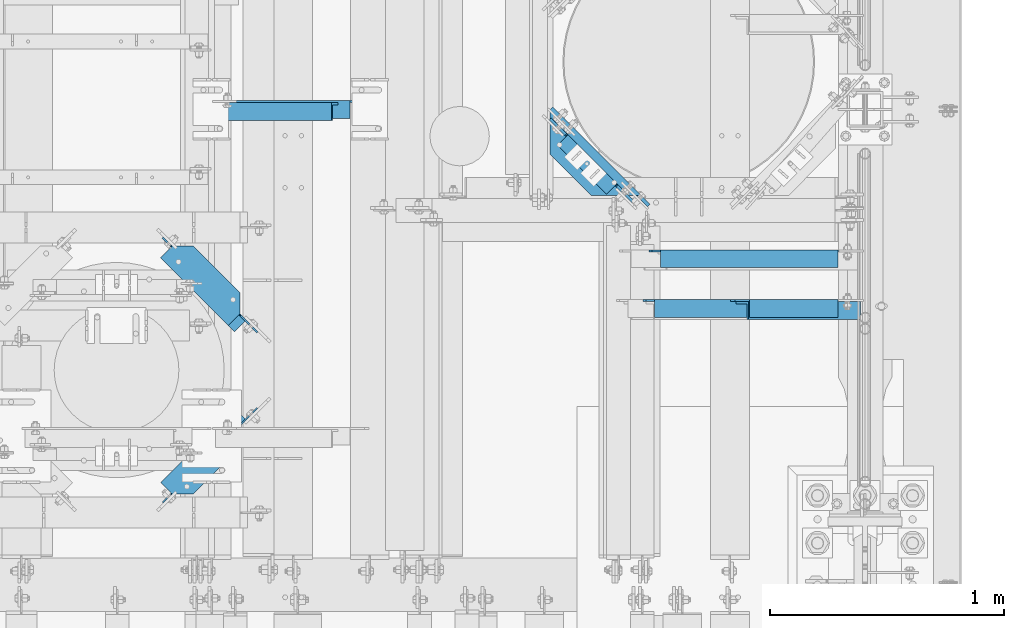
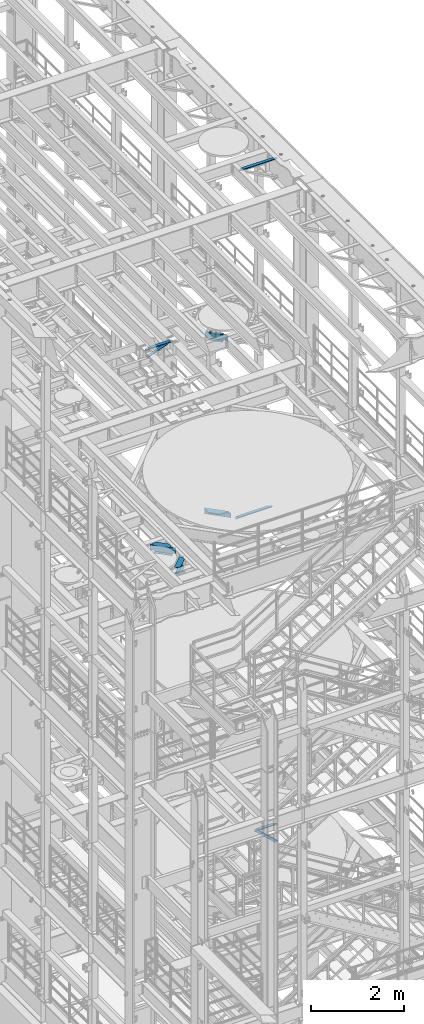
# One storey, part 1260 of 1876: 8 beams, 2 members, 10 elements without a shape of their own.
"""IFC2X3 building model written with IfcOpenShell, lengths in millimetres."""

from ifc_helpers import new_model, si_unit, frame, origin_with_axes, place, context, subcontext, project, spatial, faceted_brep, material, type_object, element, aggregate, save


model = new_model("IFC2X3")

# Units and contexts
model_context = context("Model", 3, precision=1e-05, world=origin_with_axes())
body_context = subcontext(model_context, "Body", "Model", "MODEL_VIEW")
ifc_project = project(units=[si_unit("LENGTHUNIT", "METRE", prefix="MILLI"), si_unit("AREAUNIT", "SQUARE_METRE"), si_unit("VOLUMEUNIT", "CUBIC_METRE"), si_unit("MASSUNIT", "GRAM", prefix="KILO"), si_unit("TIMEUNIT", "SECOND"), si_unit("PLANEANGLEUNIT", "RADIAN"), si_unit("SOLIDANGLEUNIT", "STERADIAN"), si_unit("THERMODYNAMICTEMPERATUREUNIT", "DEGREE_CELSIUS"), si_unit("LUMINOUSINTENSITYUNIT", "LUMEN")], contexts=[model_context])

# Site, building, storey
site_placement = place(None, origin_with_axes())
site = spatial("IfcSite", under=ifc_project, at=site_placement, CompositionType="ELEMENT")
building_placement = place(site_placement, origin_with_axes())
building = spatial("IfcBuilding", under=site, at=building_placement, Name="Undefined", CompositionType="ELEMENT")
storey_placement = place(building_placement, origin_with_axes())
storey = spatial("IfcBuildingStorey", under=building, at=storey_placement, Name="Undefined", CompositionType="ELEMENT", Elevation=0.0)

# Assembly, member
assembly_1_placement = place(storey_placement, origin_with_axes())
assembly_1 = element("IfcElementAssembly", 1, at=assembly_1_placement, inside=storey, AssemblyPlace="NOTDEFINED", PredefinedType="RIGID_FRAME")
ifc_material_1 = material(Name="STEEL/A36")
member_type = type_object("IfcMemberType", Name="L3X3X3/8", PredefinedType="NOTDEFINED")
member_1_placement = place(assembly_1_placement, frame((4825.99943782548, 3546.47297112884, 17722.85), z_axis=(0.0, -1.0, 0.0), x_axis=(0.933232749162593, -9.69999853849769e-08, 0.35927237006263)))
member_1 = element("IfcMember", 2, at=member_1_placement, type_object=member_type, material=ifc_material_1, ObjectType="L3X3X3/8", context=body_context, shape_type="Brep", body=[
    faceted_brep([(31.6783539145181, 38.0999999999167, -38.1000000000035), (31.6783539102435, 38.1000000000477, 38.0999999999967), (563.830812318436, 38.100000000677, 38.0999999999349), (563.830812322711, 38.1000000005497, -38.1000000000654), (31.6783539102325, 28.5750000000644, 38.0999999999967), (563.830812318425, 28.5750000006938, 38.0999999999349), (31.6783539139742, 28.5749999999498, -28.5750000000039), (563.830812322169, 28.575000000581, -28.5750000000658), (31.6783539139069, -38.0999999999422, -28.5750000000044), (563.830812322098, -38.0999999993164, -28.5750000000662), (31.6783539144417, -38.099999999964, -38.1000000000045), (563.830812322634, -38.0999999993292, -38.1000000000663)], [[[0, 1, 2, 3]], [[1, 4, 5, 2]], [[4, 6, 7, 5]], [[6, 8, 9, 7]], [[8, 10, 11, 9]], [[10, 0, 3, 11]], [[5, 7, 9, 11, 3, 2]], [[10, 8, 6, 4, 1, 0]]]),
])
aggregate(assembly_1, [member_1])

assembly_2_placement = place(storey_placement, origin_with_axes())
assembly_2 = element("IfcElementAssembly", 3, at=assembly_2_placement, inside=storey, AssemblyPlace="NOTDEFINED", PredefinedType="RIGID_FRAME")
member_2_placement = place(assembly_2_placement, frame((7042.14884555327, 2695.575, 5130.79999999686), z_axis=(0.0, -1.0, 0.0), x_axis=(0.726792308030797, 0.0, -0.686857293029104)))
member_2 = element("IfcMember", 4, at=member_2_placement, type_object=member_type, material=ifc_material_1, ObjectType="L3X3X3/8", context=body_context, shape_type="Brep", body=[
    faceted_brep([(72.6727188348357, 38.100000000004, -38.0999999999999), (72.6727188348357, 38.100000000004, 38.0999999999999), (731.760828651386, 38.1000000001059, 38.0999999999999), (731.760828651386, 38.1000000001059, -38.0999999999999), (72.6727188348361, 28.5750000000062, 38.0999999999999), (731.760828651386, 28.5750000001062, 38.0999999999999), (72.6727188348361, 28.5750000000062, -28.5749999999998), (731.760828651386, 28.5750000001062, -28.5749999999998), (72.6727188348361, -38.0999999999822, -28.5749999999998), (731.760828651387, -38.0999999998821, -28.5749999999998), (72.6727188348361, -38.0999999999822, -38.0999999999999), (731.760828651387, -38.0999999998821, -38.0999999999999)], [[[0, 1, 2, 3]], [[1, 4, 5, 2]], [[4, 6, 7, 5]], [[6, 8, 9, 7]], [[8, 10, 11, 9]], [[10, 0, 3, 11]], [[5, 7, 9, 11, 3, 2]], [[10, 8, 6, 4, 1, 0]]]),
])
aggregate(assembly_2, [member_2])

# Assembly, beam
assembly_3_placement = place(storey_placement, origin_with_axes())
assembly_3 = element("IfcElementAssembly", 5, at=assembly_3_placement, inside=storey, Name="ANGLE", AssemblyPlace="NOTDEFINED", PredefinedType="RIGID_FRAME")
beam_type_1 = type_object("IfcBeamType", Name="L3X3X3/8", PredefinedType="NOTDEFINED")
beam_1_placement = place(assembly_3_placement, frame((4826.00006225236, 3555.99797112877, 17945.1), z_axis=(0.0, -1.0, 0.0), x_axis=(1.0, 0.0, 0.0)))
beam_1 = element("IfcBeam", 6, at=beam_1_placement, type_object=beam_type_1, material=ifc_material_1, Name="ANGLE", ObjectType="L3X3X3/8", context=body_context, shape_type="Brep", body=[
    faceted_brep([(592.137879206581, 28.5750000000007, -28.5750000001131), (592.137886141031, 28.5750000000007, 38.0999999998871), (84.1369379238226, 28.5750017223108, 38.099999999984), (84.1369309896222, 28.5750000000007, -28.5750000000166), (592.137552829826, 38.0999999999985, 38.0999999998871), (84.1373129237786, 38.0999999999985, 38.0999999999835), (22.2249324870172, 28.5750000000007, -28.5750000000048), (22.2249314964174, 28.5750108662178, -38.1000000000049), (3.17493225935686, 9.52501162915723, -38.1000000000013), (3.17493324995667, 9.52501048616614, -28.5750000000012), (84.1369299990224, 28.5750108662141, -38.1000000000167), (84.1373049986182, 38.0999999999985, -38.1000000000167), (592.13754490474, 38.0999999999985, -38.1000000001131), (592.137934775866, 26.9870022607502, -28.5750000001131), (592.137933785266, 26.9870012415704, -38.1000000001131), (654.049937080378, 26.9870022607502, -28.5750000001249), (654.049936089778, 26.9870012415704, -38.100000000125), (673.099936317439, 7.93700302368961, -28.5750000001285), (673.099935326839, 7.93700200450985, -38.1000000001286), (673.099936317439, 1.58700264221989, -28.5750000001285), (673.099935326839, 1.58700162304012, -38.1000000001286), (673.099934791558, -38.0999999999985, -28.5750000001285), (673.099933800958, -38.0999999999985, -38.1000000001286), (3.17493098964678, -38.0999999999985, -28.5750000000012), (3.17492999904698, -38.0999999999985, -38.1000000000013), (3.17492847316589, 3.17501220136182, -38.1000000000013), (3.17492946376569, 3.17501105837073, -28.5750000000012)], [[[0, 1, 2, 3]], [[1, 4, 5, 2]], [[6, 7, 8, 9]], [[3, 10, 7, 6]], [[2, 5, 11, 10, 3]], [[4, 12, 11, 5]], [[1, 0, 13, 14, 12, 4]], [[15, 16, 14, 13]], [[17, 18, 16, 15]], [[19, 20, 18, 17]], [[20, 19, 21, 22]], [[22, 21, 23, 24]], [[8, 7, 10, 11, 12, 14, 16, 18, 20, 22, 24, 25]], [[9, 8, 25, 26]], [[21, 19, 17, 15, 13, 0, 3, 6, 9, 26, 23]], [[25, 24, 23, 26]]]),
])
aggregate(assembly_3, [beam_1])

assembly_4_placement = place(storey_placement, origin_with_axes())
assembly_4 = element("IfcElementAssembly", 7, at=assembly_4_placement, inside=storey, Name="ANGLE", AssemblyPlace="NOTDEFINED", PredefinedType="RIGID_FRAME")
beam_2_placement = place(assembly_4_placement, frame((7042.14884547182, 2705.1, 5092.69999999686), z_axis=(0.0, -1.0, 0.0), x_axis=(1.0, 0.0, 0.0)))
beam_2 = element("IfcBeam", 8, at=beam_2_placement, type_object=beam_type_1, material=ifc_material_1, Name="ANGLE", ObjectType="L3X3X3/8", context=body_context, shape_type="Brep", body=[
    faceted_brep([(461.964154830203, 28.5749999999998, -28.5749999999998), (461.964155696969, 28.5749999999998, 38.0999999999999), (84.1379236981738, 28.5750017148421, 38.1000000000004), (84.1379497680955, 28.5749999999998, -28.5749999999998), (461.964155696969, 38.1000000000004, 38.0999999999999), (84.1382986980861, 38.1000000000004, 38.0999999999999), (22.2259474792336, 28.5749999999998, -28.5749999999998), (22.225951203508, 28.5750108588118, -38.0999999999999), (3.17595196644379, 9.5250116217494, -38.0999999999999), (3.1759482421694, 9.52501047875285, -28.5749999999998), (84.1379534923708, 28.5750108588145, -38.0999999999999), (84.1383284919229, 38.1000000000004, -38.0999999999999), (461.96415470638, 38.1000000000004, -38.0999999999999), (461.964154830171, 12.6999992401979, -28.5749999999998), (461.964154706342, 12.6999992401979, -38.0999999999999), (538.957410445405, 12.6999992401979, -28.5749999999998), (538.957410321576, 12.6999992401979, -38.0999999999999), (570.707410445405, -19.0500007598021, -28.5749999999998), (570.707410321576, -19.0500007598021, -38.0999999999999), (570.707404528182, -38.1000000000004, -28.5749999999998), (570.707404528182, -38.1000000000004, -38.0999999999999), (3.17594976805049, -38.1000000000004, -28.5749999999998), (3.17595349232579, -38.1000000000004, -38.0999999999999), (3.17595196644379, 3.17501219395399, -38.0999999999999), (3.17594824216849, 3.17501105095744, -28.5749999999998)], [[[0, 1, 2, 3]], [[1, 4, 5, 2]], [[6, 7, 8, 9]], [[3, 10, 7, 6]], [[2, 5, 11, 10, 3]], [[4, 12, 11, 5]], [[1, 0, 13, 14, 12, 4]], [[15, 16, 14, 13]], [[16, 15, 17, 18]], [[18, 17, 19, 20]], [[20, 19, 21, 22]], [[8, 7, 10, 11, 12, 14, 16, 18, 20, 22, 23]], [[9, 8, 23, 24]], [[19, 17, 15, 13, 0, 3, 6, 9, 24, 21]], [[23, 22, 21, 24]]]),
])
aggregate(assembly_4, [beam_2])

assembly_5_placement = place(storey_placement, origin_with_axes())
assembly_5 = element("IfcElementAssembly", 9, at=assembly_5_placement, inside=storey, Name="ANGLE", AssemblyPlace="NOTDEFINED", PredefinedType="RIGID_FRAME")
beam_3_placement = place(assembly_5_placement, frame((6692.89999993464, 2917.825, 13271.5), z_axis=(0.0, -1.0, 0.0), x_axis=(1.0, 0.0, 0.0)))
beam_3 = element("IfcBeam", 10, at=beam_3_placement, type_object=beam_type_1, material=ifc_material_1, Name="ANGLE", ObjectType="L3X3X3/8", context=body_context, shape_type="Brep", body=[
    faceted_brep([(811.213000367367, 28.5750000000007, -28.5749999999998), (811.213001234163, 28.5750000000007, 38.0999999999999), (52.3870335430847, 28.5750001907327, 38.0999999999858), (52.3869956588824, 28.5749999999955, -28.5750000000007), (811.213001234163, 38.1000000000004, 38.0999999999999), (52.387033543122, 38.0999999999985, 38.0999999999858), (15.8749959074521, 26.988000297546, -28.5749999999998), (15.8749956502761, 26.988000297546, -38.0999999999999), (3.17499584101097, 14.2880004882809, -38.0999999999999), (3.17499609818697, 14.2880004882809, -28.5749999999998), (52.3869978987241, 26.988000297546, -28.5749999999998), (52.3869976415481, 26.988000297546, -38.0999999999999), (52.3869953826566, 38.0999999999954, -38.0999999999985), (811.213000243539, 38.1000000000004, -38.0999999999999), (811.213000367367, 12.6999992370602, -28.5749999999998), (811.213000243539, 12.6999992370602, -38.0999999999999), (888.206248353207, 12.6999992370602, -28.5749999999998), (888.206248229379, 12.6999992370602, -38.0999999999999), (919.956248353207, -19.0500007629398, -28.5749999999998), (919.956248229379, -19.0500007629398, -38.0999999999999), (919.956250065358, -38.1000000000004, -28.5749999999998), (919.956250065358, -38.1000000000004, -38.0999999999999), (3.17499999075153, -38.0999999999985, -28.5749999999998), (3.17499999075153, -38.0999999999985, -38.0999999999999), (3.17499584101097, 1.58799972534143, -38.0999999999999), (3.17499609818697, 1.58799972534143, -28.5749999999998)], [[[0, 1, 2, 3]], [[1, 4, 5, 2]], [[6, 7, 8, 9]], [[10, 11, 7, 6]], [[2, 5, 12, 11, 10, 3]], [[4, 13, 12, 5]], [[1, 0, 14, 15, 13, 4]], [[16, 17, 15, 14]], [[17, 16, 18, 19]], [[19, 18, 20, 21]], [[21, 20, 22, 23]], [[8, 7, 11, 12, 13, 15, 17, 19, 21, 23, 24]], [[9, 8, 24, 25]], [[20, 18, 16, 14, 0, 3, 10, 6, 9, 25, 22]], [[24, 23, 22, 25]]]),
])
aggregate(assembly_5, [beam_3])

assembly_6_placement = place(storey_placement, origin_with_axes())
assembly_6 = element("IfcElementAssembly", 11, at=assembly_6_placement, inside=storey, Name="ANGLE", AssemblyPlace="NOTDEFINED", PredefinedType="RIGID_FRAME")
beam_4_placement = place(assembly_6_placement, frame((6667.50000000095, 2705.1, 22517.1000001129), z_axis=(0.0, -1.0, 0.0), x_axis=(1.0, 0.0, 0.0)))
beam_4 = element("IfcBeam", 12, at=beam_4_placement, type_object=beam_type_1, material=ifc_material_1, Name="ANGLE", ObjectType="L3X3X3/8", context=body_context, shape_type="Brep", body=[
    faceted_brep([(836.613000301995, 28.5750000000007, -28.5749999999998), (836.613001168791, 28.5750000000007, 38.0999999999999), (52.3870335430847, 28.5750001907327, 38.0999999999858), (52.3869956588824, 28.5749999999955, -28.5750000000007), (836.613001168791, 38.0999999999985, 38.0999999999999), (52.387033543122, 38.0999999999985, 38.0999999999858), (15.8749936676099, 28.5749999999989, -28.5750000000007), (15.8749999382144, 28.5750001907327, -38.0999999999999), (3.17500012894925, 15.8750003814675, -38.0999999999999), (3.17500032897624, 15.8750003814675, -28.5749999999998), (52.3870393343063, 28.5750001907327, -38.1000000000149), (52.3869953826566, 38.0999999999954, -38.0999999999985), (836.613000178167, 38.0999999999985, -38.0999999999999), (836.613000301995, 12.6999991241828, -28.5749999999998), (836.613000178167, 12.6999991241828, -38.0999999999999), (913.60625591723, 12.6999991241828, -28.5749999999998), (913.606255793401, 12.6999991241828, -38.0999999999999), (945.35625591723, -19.0500008758172, -28.5749999999998), (945.356255793401, -19.0500008758172, -38.0999999999999), (945.356249999983, -38.0999999999985, -28.5749999999998), (945.356249999983, -38.0999999999985, -38.0999999999999), (3.17499999075153, -38.0999999999985, -28.5749999999998), (3.17499999075153, -38.0999999999985, -38.0999999999999), (3.17500012894925, 3.17500152587672, -38.0999999999999), (3.17500032897624, 3.17500152587672, -28.5749999999998)], [[[0, 1, 2, 3]], [[1, 4, 5, 2]], [[6, 7, 8, 9]], [[3, 10, 7, 6]], [[2, 5, 11, 10, 3]], [[4, 12, 11, 5]], [[1, 0, 13, 14, 12, 4]], [[15, 16, 14, 13]], [[16, 15, 17, 18]], [[18, 17, 19, 20]], [[20, 19, 21, 22]], [[8, 7, 10, 11, 12, 14, 16, 18, 20, 22, 23]], [[9, 8, 23, 24]], [[19, 17, 15, 13, 0, 3, 6, 9, 24, 21]], [[23, 22, 21, 24]]]),
])
aggregate(assembly_6, [beam_4])

assembly_7_placement = place(storey_placement, origin_with_axes())
assembly_7 = element("IfcElementAssembly", 13, at=assembly_7_placement, inside=storey, Name="BEAM", AssemblyPlace="NOTDEFINED", PredefinedType="RIGID_FRAME")
ifc_material_2 = material(Name="STEEL/A992")
beam_type_2 = type_object("IfcBeamType", Name="W8X18", PredefinedType="NOTDEFINED")
beam_5_placement = place(assembly_7_placement, frame((5041.9, 2300.55425635799, 13206.4125), z_axis=(0.0, 0.0, 1.0), x_axis=(-0.707104099181461, -0.707109463181462, 0.0)))
beam_5 = element("IfcBeam", 14, at=beam_5_placement, type_object=beam_type_2, material=ifc_material_2, Name="BEAM", ObjectType="W8X18", context=body_context, shape_type="Brep", body=[
    faceted_brep([(28.9934818338015, -3.174999999997, -77.7875000000022), (28.993358360286, 3.17500000000132, -77.7875000000022), (86.1428286774708, 3.17499998762423, -77.7875000000022), (86.1428286774662, -3.17499999999177, -77.7875000000022), (91.0029081955154, 3.17499998758694, -78.7542299225897), (91.0029081955117, -3.17499999999154, -78.7542299225897), (95.1230846636681, 3.17499998754352, -81.5072438230673), (95.1230846636654, -3.17499999999086, -81.5072438230673), (97.8760985641466, 3.17499998750031, -85.6274202912209), (97.8760985641429, -3.17499999999131, -85.6274202912209), (98.8428284867314, -3.17499999999086, -90.4874998092673), (98.8428284867341, 3.17499998746348, -90.4874998092673), (98.8428284867805, 3.17500000000723, -95.25), (98.8428284867814, 3.17509274755776, -103.1875), (98.8428284867869, -66.6749999999686, -103.1875), (98.8428284867869, -66.6749999999686, -95.25), (98.8428284867814, -3.17499999999109, -95.25), (483.741355979063, 66.6750000000156, -103.1875), (483.741355979063, 66.6750000000156, -95.25), (499.521676770023, 50.8945599596909, -95.25), (499.521676770023, 50.8945595016301, -103.1875), (201.37985852787, 66.6749999999925, -103.1875), (201.37985852787, 66.6750000000313, -95.25), (137.879377390637, 3.17500048591205, -103.1875), (137.879377390637, 3.17500000000996, -95.25), (499.521676770028, 3.17500000003929, -95.25), (483.741355979063, 66.6750000000156, 103.1875), (483.741355979063, 66.6750000000156, 95.25), (201.37985852787, 66.6749999999925, 95.25), (201.37985852787, 66.6750000000313, 103.1875), (547.240876123302, 3.17500000004361, 95.25), (137.879377390637, 3.17500000000996, 95.25), (137.879377390637, 3.17500048591205, 103.1875), (136.942828486811, 3.17500000000996, 95.25), (136.942828486812, 3.17500269941502, 103.1875), (124.242828677498, -3.17499999998881, 77.7874999999985), (124.242828677501, 3.17499998901485, 77.7874999999985), (28.993358360286, 3.17500000000132, 77.7874999999985), (28.9934818338015, -3.174999999997, 77.7874999999985), (129.102908195543, -3.17499999998881, 78.7542299225861), (129.102908195547, 3.17499998898802, 78.7542299225861), (133.223084663697, -3.17499999998836, 81.5072438230636), (133.223084663699, 3.17499998898916, 81.5072438230636), (135.976098564174, -3.17499999998813, 85.6274202912173), (135.976098564178, 3.17499998901781, 85.6274202912173), (136.942828486761, -3.17499999998745, 90.4874998092637), (136.942828486764, 3.17499998907033, 90.4874998092637), (547.146676770023, -66.6749999999315, 95.25), (547.146676770023, -66.6749999999315, 103.1875), (136.942828486818, -66.6749999999654, 103.1875), (136.942828486818, -66.6749999999654, 95.25), (547.146676770018, -3.1749999999538, 95.25), (136.942828486812, -3.1749999999879, 95.25), (547.240876123302, 3.17499815682095, 103.1875), (547.146676770065, -3.17499999995425, 90.4874998092655), (547.146676770069, 3.17499997963523, 90.4874998092655), (548.113406692652, -3.17499999995403, 85.6274202912191), (548.113406692656, 3.17499997923346, 85.6274202912191), (550.86642059313, -3.1749999999538, 81.5072438230654), (550.866420593134, 3.17499997889263, 81.5072438230654), (554.986597061284, -3.17499999995357, 78.7542299225879), (554.986597061287, 3.17499997866548, 78.7542299225879), (559.846676579328, -3.17499999995289, 77.7875000000004), (559.846676579332, 3.1749999785859, 77.7875000000004), (601.122206639045, -3.1749999999497, 77.7875000000004), (601.122206639281, 3.1750000000477, 77.7875000000004), (601.122206639045, -3.1749999999497, -77.7875000000004), (601.122206639281, 3.1750000000477, -77.7875000000004), (512.221676579338, -3.17499999995698, -77.7875000000004), (512.221676579342, 3.17499996473862, -77.7875000000004), (507.361597061294, -3.17499999995789, -78.7542299225879), (507.361597061296, 3.17499996467791, -78.7542299225879), (503.24142059314, -3.17499999995721, -81.5072438230654), (503.241420593144, 3.17499996447827, -81.5072438230654), (500.488406692662, -3.17499999995835, -85.6274202912191), (500.488406692665, 3.17499996416927, -85.6274202912191), (499.521676770074, -3.17499999995835, -90.4874998092655), (499.521676770079, 3.17499996379797, -90.4874998092655), (499.521676770028, -3.17499999995789, -95.25), (499.521676770033, -66.6749999999354, -95.25), (499.521676770033, -66.6749999999354, -103.1875)], [[[0, 1, 2, 3]], [[3, 2, 4, 5]], [[5, 4, 6, 7]], [[7, 6, 8, 9]], [[10, 11, 12, 13, 14, 15, 16]], [[9, 8, 11, 10]], [[17, 18, 19, 20]], [[18, 17, 21, 22]], [[22, 21, 23, 24]], [[18, 22, 24, 25, 19]], [[26, 27, 28, 29]], [[27, 30, 31, 28]], [[29, 28, 31, 32]], [[32, 31, 33, 34]], [[35, 36, 37, 38]], [[39, 40, 36, 35]], [[41, 42, 40, 39]], [[43, 44, 42, 41]], [[45, 46, 44, 43]], [[47, 48, 49, 50]], [[51, 47, 50, 52]], [[49, 34, 33, 46, 45, 52, 50]], [[48, 53, 26, 29, 32, 34, 49]], [[27, 26, 53, 30]], [[48, 47, 51, 54, 55, 30, 53]], [[56, 57, 55, 54]], [[58, 59, 57, 56]], [[60, 61, 59, 58]], [[62, 63, 61, 60]], [[64, 65, 63, 62]], [[65, 64, 66, 67]], [[66, 68, 69, 67]], [[70, 71, 69, 68]], [[72, 73, 71, 70]], [[74, 75, 73, 72]], [[76, 77, 75, 74]], [[78, 79, 80, 20, 19, 25, 77, 76]], [[79, 78, 16, 15]], [[80, 79, 15, 14]], [[23, 21, 17, 20, 80, 14, 13]], [[24, 23, 13, 12]], [[6, 4, 2, 1, 37, 36, 40, 42, 44, 46, 33, 31, 30, 55, 57, 59, 61, 63, 65, 67, 69, 71, 73, 75, 77, 25, 24, 12, 11, 8]], [[38, 37, 1, 0]], [[78, 76, 74, 72, 70, 68, 66, 64, 62, 60, 58, 56, 54, 51, 52, 45, 43, 41, 39, 35, 38, 0, 3, 5, 7, 9, 10, 16]]]),
])
aggregate(assembly_7, [beam_5])

assembly_8_placement = place(storey_placement, origin_with_axes())
assembly_8 = element("IfcElementAssembly", 15, at=assembly_8_placement, inside=storey, Name="BEAM", AssemblyPlace="NOTDEFINED", PredefinedType="RIGID_FRAME")
beam_6_placement = place(assembly_8_placement, frame((5041.9, 2582.59574364201, 13206.4125), z_axis=(0.0, 0.0, 1.0), x_axis=(-0.707104099181461, 0.707109463181462, 0.0)))
beam_6 = element("IfcBeam", 16, at=beam_6_placement, type_object=beam_type_2, material=ifc_material_2, Name="BEAM", ObjectType="W8X18", context=body_context, shape_type="Brep", body=[
    faceted_brep([(28.9933583602858, -3.17500000000109, -77.7875000000022), (28.9934818338018, 3.17499999999654, -77.7875000000022), (86.1428286774708, 3.17499998762423, -77.7875000000022), (86.1428286774662, -3.17499999999177, -77.7875000000022), (91.0029081955154, 3.17499998758694, -78.7542299225897), (91.0029081955117, -3.17499999999154, -78.7542299225897), (95.1230846636681, 3.17499998754352, -81.5072438230673), (95.1230846636654, -3.17499999999086, -81.5072438230673), (97.8760985641466, 3.17499998750031, -85.6274202912209), (97.8760985641429, -3.17499999999131, -85.6274202912209), (98.8428284867314, -3.17499999999086, -90.4874998092673), (98.8428284867341, 3.17499998746348, -90.4874998092673), (98.8428284867805, 3.17500000000723, -95.25), (98.8428284880101, 66.6749999999683, -95.25), (98.8428284880101, 66.6749999999683, -103.1875), (98.8428284880042, -3.17509274755776, -103.1875), (98.8428284867814, -3.17499999999109, -95.25), (483.741355979041, -66.6750000000384, -103.1875), (483.741355979041, -66.6750000000384, -95.25), (201.379858527849, -66.6750000000102, -95.25), (201.379858527849, -66.6750000000147, -103.1875), (499.521676769977, -50.8945595016339, -103.1875), (499.521676769977, -50.8945599597382, -95.25), (483.741355979041, -66.6750000000384, 95.25), (483.741355979041, -66.6750000000384, 103.1875), (201.379858527849, -66.6750000000102, 103.1875), (201.379858527849, -66.6750000000147, 95.25), (137.879377876005, -3.17500000001201, 95.25), (137.879377876005, -3.17500000001201, 103.1875), (136.942828488056, -3.17500269941593, 103.1875), (136.942828486812, -3.1749999999879, 95.25), (547.240876123301, -3.17500000004566, 95.25), (547.240876123301, -3.17499815664814, 103.1875), (547.146676769977, 66.674999999952, 103.1875), (136.942828488063, 66.6749999999647, 103.1875), (547.146676769977, 66.674999999952, 95.25), (547.146676769972, 3.1749999999538, 95.25), (136.942828486811, 3.17500000000996, 95.25), (136.942828488063, 66.6749999999647, 95.25), (124.242828677498, -3.17499999998881, 77.7874999999985), (124.242828677501, 3.17499998901485, 77.7874999999985), (28.9934818338018, 3.17499999999654, 77.7874999999985), (28.9933583602858, -3.17500000000109, 77.7874999999985), (129.102908195543, -3.17499999998881, 78.7542299225861), (129.102908195547, 3.17499998898802, 78.7542299225861), (133.223084663697, -3.17499999998836, 81.5072438230636), (133.223084663699, 3.17499998898916, 81.5072438230636), (135.976098564174, -3.17499999998813, 85.6274202912173), (135.976098564178, 3.17499998901781, 85.6274202912173), (136.942828486761, -3.17499999998745, 90.4874998092637), (136.942828486764, 3.17499998907033, 90.4874998092637), (547.146676770065, -3.17499999995425, 90.4874998092655), (547.146676770069, 3.17499997963523, 90.4874998092655), (548.113406692652, -3.17499999995403, 85.6274202912191), (548.113406692656, 3.17499997923346, 85.6274202912191), (550.86642059313, -3.1749999999538, 81.5072438230654), (550.866420593134, 3.17499997889263, 81.5072438230654), (554.986597061284, -3.17499999995357, 78.7542299225879), (554.986597061287, 3.17499997866548, 78.7542299225879), (559.846676579328, -3.17499999995289, 77.7875000000004), (559.846676579332, 3.1749999785859, 77.7875000000004), (601.122206639045, -3.1749999999497, 77.7875000000004), (601.122206639281, 3.1750000000477, 77.7875000000004), (601.122206639045, -3.1749999999497, -77.7875000000004), (601.122206639281, 3.1750000000477, -77.7875000000004), (512.221676579338, -3.17499999995698, -77.7875000000004), (512.221676579342, 3.17499996473862, -77.7875000000004), (507.361597061294, -3.17499999995789, -78.7542299225879), (507.361597061296, 3.17499996467791, -78.7542299225879), (503.24142059314, -3.17499999995721, -81.5072438230654), (503.241420593144, 3.17499996447827, -81.5072438230654), (500.488406692662, -3.17499999995835, -85.6274202912191), (500.488406692665, 3.17499996416927, -85.6274202912191), (499.521676770074, -3.17499999995835, -90.4874998092655), (499.521676770079, 3.17499996379797, -90.4874998092655), (499.521676770028, -3.17499999995789, -95.25), (499.521676769986, 66.6749999999565, -103.1875), (499.521676769986, 66.6749999999565, -95.25), (499.521676770028, 3.17500000003929, -95.25), (137.879377390638, -3.17500000001019, -95.25), (137.879377390637, -3.17500048591228, -103.1875)], [[[0, 1, 2, 3]], [[3, 2, 4, 5]], [[5, 4, 6, 7]], [[7, 6, 8, 9]], [[10, 11, 12, 13, 14, 15, 16]], [[9, 8, 11, 10]], [[17, 18, 19, 20]], [[18, 17, 21, 22]], [[23, 24, 25, 26]], [[27, 28, 29, 30]], [[26, 25, 28, 27]], [[31, 23, 26, 27]], [[24, 23, 31, 32]], [[28, 25, 24, 32, 33, 34, 29]], [[35, 36, 37, 38]], [[39, 40, 41, 42]], [[43, 44, 40, 39]], [[45, 46, 44, 43]], [[47, 48, 46, 45]], [[49, 50, 48, 47]], [[29, 34, 38, 37, 50, 49, 30]], [[33, 35, 38, 34]], [[32, 31, 51, 52, 36, 35, 33]], [[53, 54, 52, 51]], [[55, 56, 54, 53]], [[57, 58, 56, 55]], [[59, 60, 58, 57]], [[61, 62, 60, 59]], [[62, 61, 63, 64]], [[63, 65, 66, 64]], [[67, 68, 66, 65]], [[69, 70, 68, 67]], [[71, 72, 70, 69]], [[73, 74, 72, 71]], [[75, 22, 21, 76, 77, 78, 74, 73]], [[79, 19, 18, 22, 75]], [[19, 79, 80, 20]], [[80, 79, 16, 15]], [[76, 21, 17, 20, 80, 15, 14]], [[77, 76, 14, 13]], [[78, 77, 13, 12]], [[6, 4, 2, 1, 41, 40, 44, 46, 48, 50, 37, 36, 52, 54, 56, 58, 60, 62, 64, 66, 68, 70, 72, 74, 78, 12, 11, 8]], [[42, 41, 1, 0]], [[79, 75, 73, 71, 69, 67, 65, 63, 61, 59, 57, 55, 53, 51, 31, 27, 30, 49, 47, 45, 43, 39, 42, 0, 3, 5, 7, 9, 10, 16]]]),
])
aggregate(assembly_8, [beam_6])

assembly_9_placement = place(storey_placement, origin_with_axes())
assembly_9 = element("IfcElementAssembly", 17, at=assembly_9_placement, inside=storey, Name="BEAM", AssemblyPlace="NOTDEFINED", PredefinedType="RIGID_FRAME")
beam_type_3 = type_object("IfcBeamType", Name="C8X18.75", PredefinedType="NOTDEFINED")
beam_7_placement = place(assembly_9_placement, frame((6267.13093328547, 3485.82977524507, 17881.6), z_axis=(0.0, 0.0, 1.0), x_axis=(0.707107495686185, -0.707106066686188, 0.0)))
beam_7 = element("IfcBeam", 18, at=beam_7_placement, type_object=beam_type_3, material=ifc_material_1, Name="BEAM", ObjectType="C8X18.75", context=body_context, shape_type="Brep", body=[
    faceted_brep([(381.021960101074, 19.0500000000047, -88.9012699999985), (381.021960101074, -31.7500000000073, -97.3645499999984), (381.021960101074, -31.7500000000073, -101.599999999999), (381.021960101074, 31.7500000000073, -101.599999999999), (381.021960101074, 31.7500000000073, -82.5499998092746), (381.021960101074, 19.0500000000047, -82.5499998092746), (381.988690023662, 31.7500000000073, -77.6899202912282), (381.988690023663, 19.0500000000047, -77.6899202912282), (384.741703924143, 31.7500000000073, -73.5697438230745), (384.741703924142, 19.0500000000047, -73.5697438230745), (388.861880392299, 31.7500000000073, -70.816729922597), (388.861880392299, 19.0500000000047, -70.816729922597), (393.721959910348, 31.7500000000073, -69.8500000000095), (393.721959910348, 19.0500000000047, -69.8500000000095), (482.622896990793, 19.0500000000047, -69.8500000000095), (482.622896991032, 31.7500000000073, -69.8500000000095), (85.9506845976018, -31.7500000000073, 101.600000892915), (85.9506845976018, -31.7500000000073, 97.3645499999984), (381.021960101075, -31.7500000000073, 97.3645499999984), (381.021960101075, -31.7500000000073, 101.600000025996), (85.9506845976018, 31.7500000000073, 101.599999999999), (381.021960101074, 31.7500000000073, 101.599999999999), (85.9506845975977, 19.0500000000047, -82.5499998092746), (85.9506845975986, 31.7500000000073, -82.5499998092746), (85.9506845975986, 31.7500000000073, -101.599999999999), (85.9506845975982, -31.7500000000073, -101.599999999999), (85.9506845975982, -31.7500000000073, -97.3645499999984), (85.9506845975977, 19.0500000000047, -88.9012699999985), (84.9839546750093, 19.0500000000047, -77.6899202912282), (84.9839546750093, 31.7500000000073, -77.6899202912282), (82.2309407745295, 19.0500000000047, -73.5697438230745), (82.2309407745295, 31.7500000000073, -73.5697438230745), (78.1107643063731, 19.0500000000047, -70.816729922597), (78.1107643063735, 31.7500000000082, -70.816729922597), (73.250684788324, 19.0500000000047, -69.8500000000095), (73.2506847883244, 31.7500000000073, -69.8500000000095), (-15.6493741808774, 19.0500000000047, -69.8500000000095), (-15.6493741808779, 31.7500000000073, -69.8500000000095), (-15.6493741808774, 19.0500000000047, 69.8500000014901), (-15.6493741808779, 31.7500000000073, 69.8500000014901), (73.2506808466399, 19.0500000000047, 69.8499724096764), (73.2506808466403, 31.7500000000073, 69.8499724096764), (78.1107615751423, 19.0500000000047, 70.8167012009471), (78.1107615751419, 31.7500000000073, 70.8167012009471), (82.2309393809339, 19.0500000000047, 73.5697148391446), (82.2309393809344, 31.7500000000082, 73.5697148391446), (84.9839542979059, 19.0500000000047, 77.6898917904837), (84.9839542979068, 31.7500000000073, 77.6898917904837), (85.9506845975995, 19.0500000000047, 82.5499722189379), (85.9506845975991, 31.7500000000073, 82.5499722189379), (85.9506845976, 19.0500000000047, 88.9012699999985), (381.021960101074, 19.0500000000047, 88.9012699999985), (381.021960101074, 19.0500000000047, 82.5499998106679), (381.021960101074, 31.7500000000073, 82.5499998106679), (381.988690023665, 19.0500000000047, 77.6899202926179), (381.988690023665, 31.7500000000073, 77.6899202926179), (384.74170392415, 19.0500000000047, 73.5697438244606), (384.74170392415, 31.7500000000073, 73.5697438244606), (388.861880392313, 19.0500000000047, 70.8167299239831), (388.861880392313, 31.7500000000073, 70.8167299239831), (393.721959910369, 19.0500000000047, 69.8500000014028), (393.721959910369, 31.7500000000073, 69.8500000014028), (482.622896990793, 19.0500000000047, 69.8500000015447), (482.622896991032, 31.7500000000073, 69.8500000015447)], [[[0, 1, 2, 3, 4, 5]], [[5, 4, 6, 7]], [[7, 6, 8, 9]], [[9, 8, 10, 11]], [[11, 10, 12, 13]], [[14, 13, 12, 15]], [[16, 17, 18, 19]], [[20, 16, 19, 21]], [[22, 23, 24, 25, 26, 27]], [[28, 29, 23, 22]], [[30, 31, 29, 28]], [[32, 33, 31, 30]], [[34, 35, 33, 32]], [[36, 37, 35, 34]], [[37, 36, 38, 39]], [[40, 41, 39, 38]], [[42, 43, 41, 40]], [[44, 45, 43, 42]], [[46, 47, 45, 44]], [[48, 49, 47, 46]], [[16, 20, 49, 48, 50, 17]], [[17, 50, 51, 18]], [[19, 18, 51, 52, 53, 21]], [[54, 55, 53, 52]], [[56, 57, 55, 54]], [[58, 59, 57, 56]], [[60, 61, 59, 58]], [[62, 63, 61, 60]], [[63, 62, 14, 15]], [[10, 8, 6, 4, 3, 24, 23, 29, 31, 33, 35, 37, 39, 41, 43, 45, 47, 49, 20, 21, 53, 55, 57, 59, 61, 63, 15, 12]], [[25, 24, 3, 2]], [[26, 25, 2, 1]], [[27, 26, 1, 0]], [[62, 60, 58, 56, 54, 52, 51, 50, 48, 46, 44, 42, 40, 38, 36, 34, 32, 30, 28, 22, 27, 0, 5, 7, 9, 11, 13, 14]]]),
])
aggregate(assembly_9, [beam_7])

assembly_10_placement = place(storey_placement, origin_with_axes())
assembly_10 = element("IfcElementAssembly", 19, at=assembly_10_placement, inside=storey, Name="BEAM", AssemblyPlace="NOTDEFINED", PredefinedType="RIGID_FRAME")
beam_type_4 = type_object("IfcBeamType", Name="L6X6X5/8", PredefinedType="NOTDEFINED")
beam_8_placement = place(assembly_10_placement, frame((6207.21855174175, 3536.76171867081, 13233.4), z_axis=(-0.707106066686189, -0.707107495686184, 0.0), x_axis=(0.707107495686185, -0.707106066686188, 0.0)))
beam_8 = element("IfcBeam", 20, at=beam_8_placement, type_object=beam_type_4, material=ifc_material_1, Name="BEAM", ObjectType="L6X6X5/8", context=body_context, shape_type="Brep", body=[
    faceted_brep([(569.848877400671, 76.2000000000007, -76.200000000018), (417.4483769481, 76.2000000000007, 76.2000000000171), (417.4483769481, 60.3250000000007, 76.2000000000171), (553.973825270195, 60.3250000000007, -60.3250000000144), (553.973825270195, 57.1499998092659, -60.3250000000144), (569.848877400671, 57.1499998092659, -76.200000000018), (555.340990082623, 52.2899202912195, -60.3250000000144), (571.216042213099, 52.2899202912195, -76.2000000000171), (559.234346070597, 48.1697438230658, -60.3250000000135), (575.109398201073, 48.1697438230658, -76.2000000000171), (565.061165078306, 45.4167299225883, -60.3250000000135), (580.936217208783, 45.4167299225883, -76.2000000000171), (571.934366732073, 44.4500000000007, -60.3250000000135), (587.80941886255, 44.4500000000007, -76.2000000000171), (621.325856762443, 44.4500000000007, -60.3250000000144), (621.325856762437, 44.4500000000007, -76.200000000018), (170.359982302124, 60.3250000000007, 76.2000000000171), (170.359982302124, 76.2000000000007, 76.2000000000171), (33.8354306226888, 76.2000000000007, -60.325000000008), (33.8354306226829, 60.3250000000007, -60.3250000000135), (33.8354306226829, -76.2000000000007, -60.3250000000135), (33.8354306226897, 76.2000000000007, -76.200000000018), (33.8354306226897, -76.2000000000007, -76.200000000018), (621.325856762437, -76.2000000000007, -76.200000000018), (621.325856762443, -76.2000000000007, -60.3250000000144)], [[[0, 1, 2, 3, 4, 5]], [[5, 4, 6, 7]], [[7, 6, 8, 9]], [[9, 8, 10, 11]], [[11, 10, 12, 13]], [[14, 15, 13, 12]], [[16, 17, 18, 19]], [[20, 19, 18, 21, 22]], [[20, 22, 23, 24]], [[10, 8, 6, 4, 3, 19, 20, 24, 14, 12]], [[16, 19, 3, 2]], [[17, 16, 2, 1]], [[21, 18, 17, 1, 0]], [[23, 22, 21, 0, 5, 7, 9, 11, 13, 15]], [[24, 23, 15, 14]]]),
])
aggregate(assembly_10, [beam_8])

save(model, "model.ifc")
